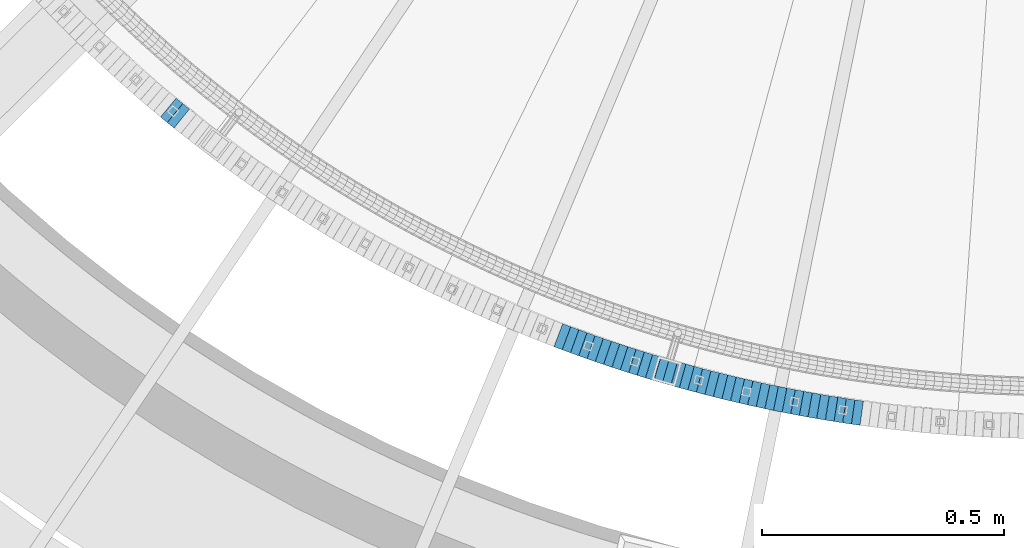
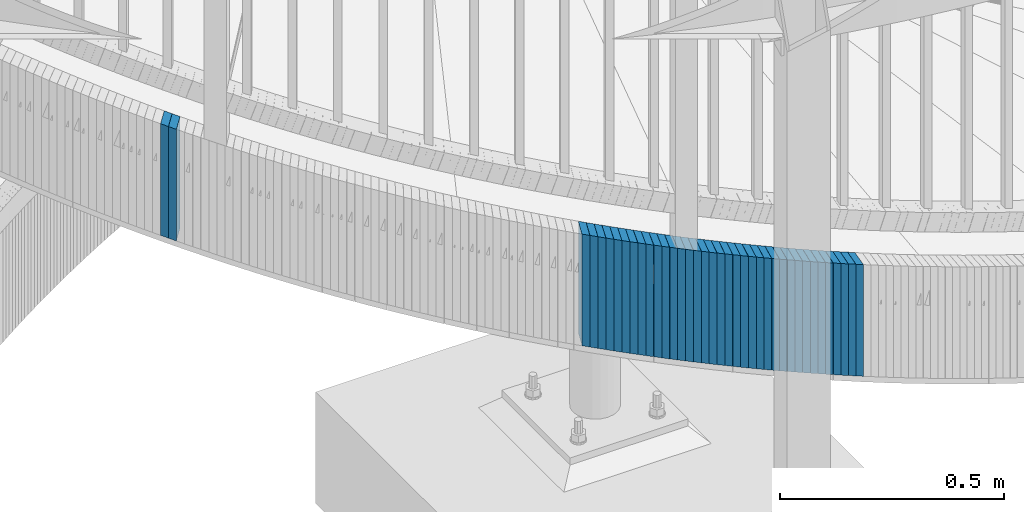
# One storey, part 876 of 975: 38 plates.
"""IFC2X3 building model written with IfcOpenShell, lengths in millimetres."""

from ifc_helpers import new_model, si_unit, frame, origin_with_axes, place, context, subcontext, project, spatial, faceted_brep, material, type_object, element, save


model = new_model("IFC2X3")

# Units and contexts
model_context = context("Model", 3, precision=1e-05, world=origin_with_axes())
body_context = subcontext(model_context, "Body", "Model", "MODEL_VIEW")
ifc_project = project(units=[si_unit("LENGTHUNIT", "METRE", prefix="MILLI"), si_unit("AREAUNIT", "SQUARE_METRE"), si_unit("VOLUMEUNIT", "CUBIC_METRE"), si_unit("MASSUNIT", "GRAM", prefix="KILO"), si_unit("TIMEUNIT", "SECOND"), si_unit("PLANEANGLEUNIT", "RADIAN"), si_unit("SOLIDANGLEUNIT", "STERADIAN"), si_unit("THERMODYNAMICTEMPERATUREUNIT", "DEGREE_CELSIUS"), si_unit("LUMINOUSINTENSITYUNIT", "LUMEN")], contexts=[model_context])

# Site, building, storey
site_placement = place(None, origin_with_axes())
site = spatial("IfcSite", under=ifc_project, at=site_placement, CompositionType="ELEMENT")
building_placement = place(site_placement, origin_with_axes())
building = spatial("IfcBuilding", under=site, at=building_placement, Name="Undefined", CompositionType="ELEMENT")
storey_placement = place(building_placement, origin_with_axes())
storey = spatial("IfcBuildingStorey", under=building, at=storey_placement, Name="Undefined", CompositionType="ELEMENT", Elevation=0.0)

# Plates
ifc_material = material(Name="STEEL/A36")
plate_type = type_object("IfcPlateType", PredefinedType="NOTDEFINED")
plate_1_placement = place(storey_placement, frame((32917.5994510154, 1181.15007153534, 3687.8875000677), z_axis=(-0.773707440821246, 0.633543049853629, 0.0), x_axis=(0.0, 0.0, 1.0)))
element("IfcPlate", 1, at=plate_1_placement, inside=storey, type_object=plate_type, material=ifc_material, Name="WALL", context=body_context, shape_type="Brep", body=[
    faceted_brep([(0.0, -25.3999999999724, -1.81898940354586e-11), (5.80000019073486, -25.3999999999614, 17.8392829894583), (5.80000019073486, 25.3999999999578, 17.8392829895529), (0.0, 25.3999999999869, 1.45519152283669e-11), (310.600006103516, -25.3999999999614, 17.8392829894583), (310.600006103516, 25.3999999999578, 17.8392829895529), (304.799987792969, -25.3999999999724, -1.81898940354586e-11), (304.799987792969, 25.3999999999869, 1.45519152283669e-11)], [[[0, 1, 2, 3]], [[1, 4, 5, 2]], [[4, 6, 7, 5]], [[6, 0, 3, 7]], [[5, 7, 3, 2]], [[6, 4, 1, 0]]]),
])
plate_2_placement = place(storey_placement, frame((32931.5690543683, 1169.79328279068, 3682.1875000677), z_axis=(-0.775943218161469, 0.630802760131266, 0.0), x_axis=(0.0, 0.0, 1.0)))
element("IfcPlate", 2, at=plate_2_placement, inside=storey, type_object=plate_type, material=ifc_material, Name="WALL", context=body_context, shape_type="Brep", body=[
    faceted_brep([(0.0, -25.3999999999724, -1.81898940354586e-11), (5.69999980926514, -25.4000000000633, 17.9075393677485), (5.69999980926514, 25.3999999999905, 17.9075393676903), (0.0, 25.3999999999869, 1.45519152283669e-11), (310.5, -25.4000000000633, 17.9075393677485), (310.5, 25.3999999999905, 17.9075393676903), (304.799987792969, -25.3999999999724, -1.81898940354586e-11), (304.799987792969, 25.3999999999869, 1.45519152283669e-11)], [[[0, 1, 2, 3]], [[1, 4, 5, 2]], [[4, 6, 7, 5]], [[6, 0, 3, 7]], [[5, 7, 3, 2]], [[6, 4, 1, 0]]]),
])
plate_3_placement = place(storey_placement, frame((33727.3261406016, 715.337070082872, 3389.5875000677), z_axis=(-0.935636632330691, 0.35296471812475, 0.0), x_axis=(0.0, 0.0, 1.0)))
element("IfcPlate", 3, at=plate_3_placement, inside=storey, type_object=plate_type, material=ifc_material, Name="WALL", context=body_context, shape_type="Brep", body=[
    faceted_brep([(0.0, -25.3999999999724, -1.81898940354586e-11), (5.80000019073486, -25.4000000000306, 17.853010177645), (5.80000019073486, 25.3999999999578, 17.8530101776596), (0.0, 25.3999999999869, 1.45519152283669e-11), (310.600006103516, -25.4000000000306, 17.853010177645), (310.600006103516, 25.3999999999578, 17.8530101776596), (304.799987792969, -25.3999999999724, -1.81898940354586e-11), (304.799987792969, 25.3999999999869, 1.45519152283669e-11)], [[[0, 1, 2, 3]], [[1, 4, 5, 2]], [[4, 6, 7, 5]], [[6, 0, 3, 7]], [[5, 7, 3, 2]], [[6, 4, 1, 0]]]),
])
plate_4_placement = place(storey_placement, frame((33744.2973835295, 709.073172312041, 3383.8875000677), z_axis=(-0.938152292731597, 0.346222869900947, 0.0), x_axis=(0.0, 0.0, 1.0)))
element("IfcPlate", 4, at=plate_4_placement, inside=storey, type_object=plate_type, material=ifc_material, Name="WALL", context=body_context, shape_type="Brep", body=[
    faceted_brep([(0.0, -25.3999999999724, -1.81898940354586e-11), (5.69999980926514, -25.4000000000633, 17.9075393677485), (5.69999980926514, 25.3999999999905, 17.9075393676903), (0.0, 25.3999999999869, 1.45519152283669e-11), (310.5, -25.4000000000633, 17.9075393677485), (310.5, 25.3999999999905, 17.9075393676903), (304.799987792969, -25.3999999999724, -1.81898940354586e-11), (304.799987792969, 25.3999999999869, 1.45519152283669e-11)], [[[0, 1, 2, 3]], [[1, 4, 5, 2]], [[4, 6, 7, 5]], [[6, 0, 3, 7]], [[5, 7, 3, 2]], [[6, 4, 1, 0]]]),
])
plate_5_placement = place(storey_placement, frame((33761.2225821276, 702.927341048499, 3378.1875000677), z_axis=(-0.939956673199756, 0.34129379207253, 0.0), x_axis=(0.0, 0.0, 1.0)))
element("IfcPlate", 5, at=plate_5_placement, inside=storey, type_object=plate_type, material=ifc_material, Name="WALL", context=body_context, shape_type="Brep", body=[
    faceted_brep([(0.0, -25.3999999999724, -1.81898940354586e-11), (5.69999980926514, -25.3999999999469, 17.8731651305425), (5.69999980926514, 25.3999999999869, 17.8731651306334), (0.0, 25.3999999999869, 1.45519152283669e-11), (310.5, -25.3999999999469, 17.8731651305425), (310.5, 25.3999999999869, 17.8731651306334), (304.799987792969, -25.3999999999724, -1.81898940354586e-11), (304.799987792969, 25.3999999999869, 1.45519152283669e-11)], [[[0, 1, 2, 3]], [[1, 4, 5, 2]], [[4, 6, 7, 5]], [[6, 0, 3, 7]], [[5, 7, 3, 2]], [[6, 4, 1, 0]]]),
])
plate_6_placement = place(storey_placement, frame((33778.1484999537, 696.881995992036, 3372.4875000677), z_axis=(-0.941741911640086, 0.33633639687146, 0.0), x_axis=(0.0, 0.0, 1.0)))
element("IfcPlate", 6, at=plate_6_placement, inside=storey, type_object=plate_type, material=ifc_material, Name="WALL", context=body_context, shape_type="Brep", body=[
    faceted_brep([(0.0, -25.3999999999724, -1.81898940354586e-11), (5.69999980926514, -25.3999999999651, 17.8440475463649), (5.69999980926514, 25.3999999999942, 17.8440475463904), (0.0, 25.3999999999869, 1.45519152283669e-11), (310.5, -25.3999999999651, 17.8440475463649), (310.5, 25.3999999999942, 17.8440475463904), (304.799987792969, -25.3999999999724, -1.81898940354586e-11), (304.799987792969, 25.3999999999869, 1.45519152283669e-11)], [[[0, 1, 2, 3]], [[1, 4, 5, 2]], [[4, 6, 7, 5]], [[6, 0, 3, 7]], [[5, 7, 3, 2]], [[6, 4, 1, 0]]]),
])
plate_7_placement = place(storey_placement, frame((33795.2195080317, 690.921609175996, 3366.6875000677), z_axis=(-0.944119345339113, 0.32960379511839, 0.0), x_axis=(0.0, 0.0, 1.0)))
element("IfcPlate", 7, at=plate_7_placement, inside=storey, type_object=plate_type, material=ifc_material, Name="WALL", context=body_context, shape_type="Brep", body=[
    faceted_brep([(0.0, -25.3999999999724, -1.81898940354586e-11), (5.80000019073486, -25.399999999936, 17.9011173247382), (5.80000019073486, 25.3999999999578, 17.9011173248837), (0.0, 25.3999999999869, 1.45519152283669e-11), (310.600006103516, -25.399999999936, 17.9011173247382), (310.600006103516, 25.3999999999578, 17.9011173248837), (304.799987792969, -25.3999999999724, -1.81898940354586e-11), (304.799987792969, 25.3999999999869, 1.45519152283669e-11)], [[[0, 1, 2, 3]], [[1, 4, 5, 2]], [[4, 6, 7, 5]], [[6, 0, 3, 7]], [[5, 7, 3, 2]], [[6, 4, 1, 0]]]),
])
plate_8_placement = place(storey_placement, frame((33812.246338152, 685.077706783121, 3360.9875000677), z_axis=(-0.945847786021473, 0.324610483007371, 0.0), x_axis=(0.0, 0.0, 1.0)))
element("IfcPlate", 8, at=plate_8_placement, inside=storey, type_object=plate_type, material=ifc_material, Name="WALL", context=body_context, shape_type="Brep", body=[
    faceted_brep([(0.0, -25.3999999999724, -1.81898940354586e-11), (5.69999980926514, -25.3999999999469, 17.8731651305425), (5.69999980926514, 25.3999999999869, 17.8731651306334), (0.0, 25.3999999999869, 1.45519152283669e-11), (310.5, -25.3999999999469, 17.8731651305425), (310.5, 25.3999999999869, 17.8731651306334), (304.799987792969, -25.3999999999724, -1.81898940354586e-11), (304.799987792969, 25.3999999999869, 1.45519152283669e-11)], [[[0, 1, 2, 3]], [[1, 4, 5, 2]], [[4, 6, 7, 5]], [[6, 0, 3, 7]], [[5, 7, 3, 2]], [[6, 4, 1, 0]]]),
])
plate_9_placement = place(storey_placement, frame((33829.2738614256, 679.334319031941, 3355.2875000677), z_axis=(-0.947555965244538, 0.319589882082478, 0.0), x_axis=(0.0, 0.0, 1.0)))
element("IfcPlate", 9, at=plate_9_placement, inside=storey, type_object=plate_type, material=ifc_material, Name="WALL", context=body_context, shape_type="Brep", body=[
    faceted_brep([(0.0, -25.3999999999724, -1.81898940354586e-11), (5.69999980926514, -25.3999999999651, 17.8440475463649), (5.69999980926514, 25.3999999999942, 17.8440475463904), (0.0, 25.3999999999869, 1.45519152283669e-11), (310.5, -25.3999999999651, 17.8440475463649), (310.5, 25.3999999999942, 17.8440475463904), (304.799987792969, -25.3999999999724, -1.81898940354586e-11), (304.799987792969, 25.3999999999869, 1.45519152283669e-11)], [[[0, 1, 2, 3]], [[1, 4, 5, 2]], [[4, 6, 7, 5]], [[6, 0, 3, 7]], [[5, 7, 3, 2]], [[6, 4, 1, 0]]]),
])
plate_10_placement = place(storey_placement, frame((33846.5728091878, 673.735549774451, 3349.4875000677), z_axis=(-0.951444518718076, 0.30782028490879, 0.0), x_axis=(0.0, 0.0, 1.0)))
element("IfcPlate", 10, at=plate_10_placement, inside=storey, type_object=plate_type, material=ifc_material, Name="WALL", context=body_context, shape_type="Brep", body=[
    faceted_brep([(0.0, -25.3999999999724, -1.81898940354586e-11), (5.80000019073486, -25.3999999999705, 17.873443603421), (5.80000019073486, 25.3999999999924, 17.8734436035338), (0.0, 25.3999999999869, 1.45519152283669e-11), (310.600006103516, -25.3999999999705, 17.873443603421), (310.600006103516, 25.3999999999924, 17.8734436035338), (304.799987792969, -25.3999999999724, -1.81898940354586e-11), (304.799987792969, 25.3999999999869, 1.45519152283669e-11)], [[[0, 1, 2, 3]], [[1, 4, 5, 2]], [[4, 6, 7, 5]], [[6, 0, 3, 7]], [[5, 7, 3, 2]], [[6, 4, 1, 0]]]),
])
plate_11_placement = place(storey_placement, frame((33863.5728091818, 668.235549775147, 3343.7875000677), z_axis=(-0.951444518718076, 0.30782028490879, 0.0), x_axis=(0.0, 0.0, 1.0)))
element("IfcPlate", 11, at=plate_11_placement, inside=storey, type_object=plate_type, material=ifc_material, Name="WALL", context=body_context, shape_type="Brep", body=[
    faceted_brep([(0.0, -25.3999999999724, -1.81898940354586e-11), (5.69999980926514, -25.3999999999469, 17.8731651305425), (5.69999980926514, 25.3999999999869, 17.8731651306334), (0.0, 25.3999999999869, 1.45519152283669e-11), (310.5, -25.3999999999469, 17.8731651305425), (310.5, 25.3999999999869, 17.8731651306334), (304.799987792969, -25.3999999999724, -1.81898940354586e-11), (304.799987792969, 25.3999999999869, 1.45519152283669e-11)], [[[0, 1, 2, 3]], [[1, 4, 5, 2]], [[4, 6, 7, 5]], [[6, 0, 3, 7]], [[5, 7, 3, 2]], [[6, 4, 1, 0]]]),
])
plate_12_placement = place(storey_placement, frame((33880.9718300514, 662.840843235734, 3338.0875000677), z_axis=(-0.95517312266217, 0.296047809895292, 0.0), x_axis=(0.0, 0.0, 1.0)))
element("IfcPlate", 12, at=plate_12_placement, inside=storey, type_object=plate_type, material=ifc_material, Name="WALL", context=body_context, shape_type="Brep", body=[
    faceted_brep([(0.0, -25.3999999999724, -1.81898940354586e-11), (5.69999980926514, -25.3999999999978, 17.9011173248218), (5.69999980926514, 25.4000000000087, 17.9011173248182), (0.0, 25.3999999999869, 1.45519152283669e-11), (310.5, -25.3999999999978, 17.9011173248218), (310.5, 25.4000000000087, 17.9011173248182), (304.799987792969, -25.3999999999724, -1.81898940354586e-11), (304.799987792969, 25.3999999999869, 1.45519152283669e-11)], [[[0, 1, 2, 3]], [[1, 4, 5, 2]], [[4, 6, 7, 5]], [[6, 0, 3, 7]], [[5, 7, 3, 2]], [[6, 4, 1, 0]]]),
])
plate_13_placement = place(storey_placement, frame((33898.0718300557, 657.540843236489, 3332.2875000677), z_axis=(-0.95517312266217, 0.296047809895292, 0.0), x_axis=(0.0, 0.0, 1.0)))
element("IfcPlate", 13, at=plate_13_placement, inside=storey, type_object=plate_type, material=ifc_material, Name="WALL", context=body_context, shape_type="Brep", body=[
    faceted_brep([(0.0, -25.3999999999724, -1.81898940354586e-11), (5.80000019073486, -25.399999999936, 17.9011173247382), (5.80000019073486, 25.3999999999578, 17.9011173248837), (0.0, 25.3999999999869, 1.45519152283669e-11), (310.600006103516, -25.399999999936, 17.9011173247382), (310.600006103516, 25.3999999999578, 17.9011173248837), (304.799987792969, -25.3999999999724, -1.81898940354586e-11), (304.799987792969, 25.3999999999869, 1.45519152283669e-11)], [[[0, 1, 2, 3]], [[1, 4, 5, 2]], [[4, 6, 7, 5]], [[6, 0, 3, 7]], [[5, 7, 3, 2]], [[6, 4, 1, 0]]]),
])
plate_14_placement = place(storey_placement, frame((33915.4319943448, 652.361731430617, 3326.5875000677), z_axis=(-0.958287760646571, 0.285805122058686, -5.19926288689022e-11), x_axis=(0.0, 0.0, 1.0)))
element("IfcPlate", 14, at=plate_14_placement, inside=storey, type_object=plate_type, material=ifc_material, Name="WALL", context=body_context, shape_type="Brep", body=[
    faceted_brep([(0.0, -25.3999999999724, -1.81898940354586e-11), (5.69999980926514, -25.3999999999651, 17.8440475463649), (5.69999980926514, 25.3999999999942, 17.8440475463904), (0.0, 25.3999999999869, 1.45519152283669e-11), (310.5, -25.3999999999651, 17.8440475463649), (310.5, 25.3999999999942, 17.8440475463904), (304.799987792969, -25.3999999999724, -1.81898940354586e-11), (304.799987792969, 25.3999999999869, 1.45519152283669e-11)], [[[0, 1, 2, 3]], [[1, 4, 5, 2]], [[4, 6, 7, 5]], [[6, 0, 3, 7]], [[5, 7, 3, 2]], [[6, 4, 1, 0]]]),
])
plate_15_placement = place(storey_placement, frame((33932.8012284135, 647.311897447003, 3320.7875000677), z_axis=(-0.96024972858431, 0.279142362879158, 0.0), x_axis=(0.0, 0.0, 1.0)))
element("IfcPlate", 15, at=plate_15_placement, inside=storey, type_object=plate_type, material=ifc_material, Name="WALL", context=body_context, shape_type="Brep", body=[
    faceted_brep([(0.0, -25.3999999999724, -1.81898940354586e-11), (5.80000019073486, -25.3999999999905, 17.9067020416114), (5.80000019073486, 25.399999999976, 17.9067020416369), (0.0, 25.3999999999869, 1.45519152283669e-11), (310.600006103516, -25.3999999999905, 17.9067020416114), (310.600006103516, 25.399999999976, 17.9067020416369), (304.799987792969, -25.3999999999724, -1.81898940354586e-11), (304.799987792969, 25.3999999999869, 1.45519152283669e-11)], [[[0, 1, 2, 3]], [[1, 4, 5, 2]], [[4, 6, 7, 5]], [[6, 0, 3, 7]], [[5, 7, 3, 2]], [[6, 4, 1, 0]]]),
])
plate_16_placement = place(storey_placement, frame((33950.0012284237, 642.311897446904, 3315.0875000677), z_axis=(-0.96024972858431, 0.279142362879158, 0.0), x_axis=(0.0, 0.0, 1.0)))
element("IfcPlate", 16, at=plate_16_placement, inside=storey, type_object=plate_type, material=ifc_material, Name="WALL", context=body_context, shape_type="Brep", body=[
    faceted_brep([(0.0, -25.3999999999724, -1.81898940354586e-11), (5.69999980926514, -25.4000000000633, 17.9075393677485), (5.69999980926514, 25.3999999999905, 17.9075393676903), (0.0, 25.3999999999869, 1.45519152283669e-11), (310.5, -25.4000000000633, 17.9075393677485), (310.5, 25.3999999999905, 17.9075393676903), (304.799987792969, -25.3999999999724, -1.81898940354586e-11), (304.799987792969, 25.3999999999869, 1.45519152283669e-11)], [[[0, 1, 2, 3]], [[1, 4, 5, 2]], [[4, 6, 7, 5]], [[6, 0, 3, 7]], [[5, 7, 3, 2]], [[6, 4, 1, 0]]]),
])
plate_17_placement = place(storey_placement, frame((33967.6005873547, 637.426859859257, 3309.3875000677), z_axis=(-0.963597665099577, 0.267356578027627, 0.0), x_axis=(0.0, 0.0, 1.0)))
element("IfcPlate", 17, at=plate_17_placement, inside=storey, type_object=plate_type, material=ifc_material, Name="WALL", context=body_context, shape_type="Brep", body=[
    faceted_brep([(0.0, -25.3999999999724, -1.81898940354586e-11), (5.69999980926514, -25.4000000000342, 17.9493732452938), (5.69999980926514, 25.4000000000415, 17.9493732451738), (0.0, 25.3999999999869, 1.45519152283669e-11), (310.5, -25.4000000000342, 17.9493732452938), (310.5, 25.4000000000415, 17.9493732451738), (304.799987792969, -25.3999999999724, -1.81898940354586e-11), (304.799987792969, 25.3999999999869, 1.45519152283669e-11)], [[[0, 1, 2, 3]], [[1, 4, 5, 2]], [[4, 6, 7, 5]], [[6, 0, 3, 7]], [[5, 7, 3, 2]], [[6, 4, 1, 0]]]),
])
for number, where, z_axis, x_axis, name in (
    (18, (33985.0322430294, 632.69071190803, 3303.5875000677), (-0.965020812823148, 0.262173283951953, 0.0), (0.0, 0.0, 1.0), "WALL"),
    (19, (34002.3322430346, 627.990711908945, 3297.7875000677), (-0.965020812823148, 0.262173283951953, 0.0), (0.0, 0.0, 1.0), "WALL"),
):
    element("IfcPlate", number, at=place(storey_placement, frame(where, z_axis=z_axis, x_axis=x_axis)), inside=storey, type_object=plate_type, material=ifc_material, Name=name, context=body_context, shape_type="Brep", body=[
        faceted_brep([(0.0, -25.3999999999724, -1.81898940354586e-11), (5.80000019073486, -25.3999999999833, 17.9287471770986), (5.80000019073486, 25.4000000000087, 17.9287471771167), (0.0, 25.3999999999869, 1.45519152283669e-11), (310.600006103516, -25.3999999999833, 17.9287471770986), (310.600006103516, 25.4000000000087, 17.9287471771167), (304.799987792969, -25.3999999999724, -1.81898940354586e-11), (304.799987792969, 25.3999999999869, 1.45519152283669e-11)], [[[0, 1, 2, 3]], [[1, 4, 5, 2]], [[4, 6, 7, 5]], [[6, 0, 3, 7]], [[5, 7, 3, 2]], [[6, 4, 1, 0]]]),
    ])
plate_18_placement = place(storey_placement, frame((34020.0317207628, 623.41130900027, 3292.0875000677), z_axis=(-0.968146911628319, 0.250382821903876, 0.0), x_axis=(0.0, 0.0, 1.0)))
element("IfcPlate", 20, at=plate_18_placement, inside=storey, type_object=plate_type, material=ifc_material, Name="WALL", context=body_context, shape_type="Brep", body=[
    faceted_brep([(0.0, -25.3999999999724, -1.81898940354586e-11), (5.69999980926514, -25.3999999999978, 17.9738693237196), (5.69999980926514, 25.4000000000178, 17.9738693236577), (0.0, 25.3999999999869, 1.45519152283669e-11), (310.5, -25.3999999999978, 17.9738693237196), (310.5, 25.4000000000178, 17.9738693236577), (304.799987792969, -25.3999999999724, -1.81898940354586e-11), (304.799987792969, 25.3999999999869, 1.45519152283669e-11)], [[[0, 1, 2, 3]], [[1, 4, 5, 2]], [[4, 6, 7, 5]], [[6, 0, 3, 7]], [[5, 7, 3, 2]], [[6, 4, 1, 0]]]),
])
plate_19_placement = place(storey_placement, frame((34037.4306501892, 618.985935893361, 3286.3875000677), z_axis=(-0.969145852858996, 0.246487962964138, 0.0), x_axis=(0.0, 0.0, 1.0)))
element("IfcPlate", 21, at=plate_19_placement, inside=storey, type_object=plate_type, material=ifc_material, Name="WALL", context=body_context, shape_type="Brep", body=[
    faceted_brep([(0.0, -25.3999999999724, -1.81898940354586e-11), (5.69999980926514, -25.4000000000196, 17.8538513183848), (5.69999980926514, 25.4000000000415, 17.8538513183157), (0.0, 25.3999999999869, 1.45519152283669e-11), (310.5, -25.4000000000196, 17.8538513183848), (310.5, 25.4000000000415, 17.8538513183157), (304.799987792969, -25.3999999999724, -1.81898940354586e-11), (304.799987792969, 25.3999999999869, 1.45519152283669e-11)], [[[0, 1, 2, 3]], [[1, 4, 5, 2]], [[4, 6, 7, 5]], [[6, 0, 3, 7]], [[5, 7, 3, 2]], [[6, 4, 1, 0]]]),
])
plate_20_placement = place(storey_placement, frame((34054.9977509856, 614.644039084407, 3280.5875000677), z_axis=(-0.970795333552335, 0.23990919188937, 0.0), x_axis=(0.0, 0.0, 1.0)))
element("IfcPlate", 22, at=plate_20_placement, inside=storey, type_object=plate_type, material=ifc_material, Name="WALL", context=body_context, shape_type="Brep", body=[
    faceted_brep([(0.0, -25.3999999999724, -1.81898940354586e-11), (5.80000019073486, -25.4000000000233, 17.9178676605334), (5.80000019073486, 25.3999999999942, 17.9178676605297), (0.0, 25.3999999999869, 1.45519152283669e-11), (310.600006103516, -25.4000000000233, 17.9178676605334), (310.600006103516, 25.3999999999942, 17.9178676605297), (304.799987792969, -25.3999999999724, -1.81898940354586e-11), (304.799987792969, 25.3999999999869, 1.45519152283669e-11)], [[[0, 1, 2, 3]], [[1, 4, 5, 2]], [[4, 6, 7, 5]], [[6, 0, 3, 7]], [[5, 7, 3, 2]], [[6, 4, 1, 0]]]),
])
plate_21_placement = place(storey_placement, frame((34072.3977509968, 610.344039084932, 3274.8875000677), z_axis=(-0.970795333552335, 0.23990919188937, 0.0), x_axis=(0.0, 0.0, 1.0)))
element("IfcPlate", 23, at=plate_21_placement, inside=storey, type_object=plate_type, material=ifc_material, Name="WALL", context=body_context, shape_type="Brep", body=[
    faceted_brep([(0.0, -25.3999999999724, -1.81898940354586e-11), (5.69999980926514, -25.3999999999724, 17.9212169646999), (5.69999980926514, 25.3999999999651, 17.9212169647544), (0.0, 25.3999999999869, 1.45519152283669e-11), (310.5, -25.3999999999724, 17.9212169646999), (310.5, 25.3999999999651, 17.9212169647544), (304.799987792969, -25.3999999999724, -1.81898940354586e-11), (304.799987792969, 25.3999999999869, 1.45519152283669e-11)], [[[0, 1, 2, 3]], [[1, 4, 5, 2]], [[4, 6, 7, 5]], [[6, 0, 3, 7]], [[5, 7, 3, 2]], [[6, 4, 1, 0]]]),
])
plate_22_placement = place(storey_placement, frame((34090.2007954729, 606.247917420197, 3269.0875000677), z_axis=(-0.974579651097025, 0.224041299022304, 0.0), x_axis=(0.0, 0.0, 1.0)))
element("IfcPlate", 24, at=plate_22_placement, inside=storey, type_object=plate_type, material=ifc_material, Name="WALL", context=body_context, shape_type="Brep", body=[
    faceted_brep([(0.0, -25.3999999999724, -1.81898940354586e-11), (5.80000019073486, -25.4000000000306, 17.853010177645), (5.80000019073486, 25.3999999999578, 17.8530101776596), (0.0, 25.3999999999869, 1.45519152283669e-11), (310.600006103516, -25.4000000000306, 17.853010177645), (310.600006103516, 25.3999999999578, 17.8530101776596), (304.799987792969, -25.3999999999724, -1.81898940354586e-11), (304.799987792969, 25.3999999999869, 1.45519152283669e-11)], [[[0, 1, 2, 3]], [[1, 4, 5, 2]], [[4, 6, 7, 5]], [[6, 0, 3, 7]], [[5, 7, 3, 2]], [[6, 4, 1, 0]]]),
])
plate_23_placement = place(storey_placement, frame((34107.6007954703, 602.247917420198, 3263.3875000677), z_axis=(-0.974579651097025, 0.224041299022304, 0.0), x_axis=(0.0, 0.0, 1.0)))
element("IfcPlate", 25, at=plate_23_placement, inside=storey, type_object=plate_type, material=ifc_material, Name="WALL", context=body_context, shape_type="Brep", body=[
    faceted_brep([(0.0, -25.3999999999724, -1.81898940354586e-11), (5.69999980926514, -25.4000000000196, 17.8538513183848), (5.69999980926514, 25.4000000000415, 17.8538513183157), (0.0, 25.3999999999869, 1.45519152283669e-11), (310.5, -25.4000000000196, 17.8538513183848), (310.5, 25.4000000000415, 17.8538513183157), (304.799987792969, -25.3999999999724, -1.81898940354586e-11), (304.799987792969, 25.3999999999869, 1.45519152283669e-11)], [[[0, 1, 2, 3]], [[1, 4, 5, 2]], [[4, 6, 7, 5]], [[6, 0, 3, 7]], [[5, 7, 3, 2]], [[6, 4, 1, 0]]]),
])
plate_24_placement = place(storey_placement, frame((34125.2664117393, 598.310427121475, 3257.6875000677), z_axis=(-0.976055647129105, 0.217520973028772, 0.0), x_axis=(0.0, 0.0, 1.0)))
element("IfcPlate", 26, at=plate_24_placement, inside=storey, type_object=plate_type, material=ifc_material, Name="WALL", context=body_context, shape_type="Brep", body=[
    faceted_brep([(0.0, -25.3999999999724, -1.81898940354586e-11), (5.69999980926514, -25.3999999999896, 17.9334888457815), (5.69999980926514, 25.3999999999869, 17.9334888458907), (0.0, 25.3999999999869, 1.45519152283669e-11), (310.5, -25.3999999999896, 17.9334888457815), (310.5, 25.3999999999869, 17.9334888458907), (304.799987792969, -25.3999999999724, -1.81898940354586e-11), (304.799987792969, 25.3999999999869, 1.45519152283669e-11)], [[[0, 1, 2, 3]], [[1, 4, 5, 2]], [[4, 6, 7, 5]], [[6, 0, 3, 7]], [[5, 7, 3, 2]], [[6, 4, 1, 0]]]),
])
plate_25_placement = place(storey_placement, frame((34142.9016202032, 594.480681491046, 3251.8875000677), z_axis=(-0.97722673497773, 0.212197804995164, 0.0), x_axis=(0.0, 0.0, 1.0)))
element("IfcPlate", 27, at=plate_25_placement, inside=storey, type_object=plate_type, material=ifc_material, Name="WALL", context=body_context, shape_type="Brep", body=[
    faceted_brep([(0.0, -25.3999999999724, -1.81898940354586e-11), (5.80000019073486, -25.3999999999905, 17.9067020416114), (5.80000019073486, 25.399999999976, 17.9067020416369), (0.0, 25.3999999999869, 1.45519152283669e-11), (310.600006103516, -25.3999999999905, 17.9067020416114), (310.600006103516, 25.399999999976, 17.9067020416369), (304.799987792969, -25.3999999999724, -1.81898940354586e-11), (304.799987792969, 25.3999999999869, 1.45519152283669e-11)], [[[0, 1, 2, 3]], [[1, 4, 5, 2]], [[4, 6, 7, 5]], [[6, 0, 3, 7]], [[5, 7, 3, 2]], [[6, 4, 1, 0]]]),
])
plate_26_placement = place(storey_placement, frame((34160.673471648, 590.823206123946, 3246.1875000677), z_axis=(-0.979489544723104, 0.20149499194304, 0.0), x_axis=(0.0, 0.0, 1.0)))
element("IfcPlate", 28, at=plate_26_placement, inside=storey, type_object=plate_type, material=ifc_material, Name="WALL", context=body_context, shape_type="Brep", body=[
    faceted_brep([(0.0, -25.3999999999724, -1.81898940354586e-11), (5.69999980926514, -25.3999999999469, 17.8731651305425), (5.69999980926514, 25.3999999999869, 17.8731651306334), (0.0, 25.3999999999869, 1.45519152283669e-11), (310.5, -25.3999999999469, 17.8731651305425), (310.5, 25.3999999999869, 17.8731651306334), (304.799987792969, -25.3999999999724, -1.81898940354586e-11), (304.799987792969, 25.3999999999869, 1.45519152283669e-11)], [[[0, 1, 2, 3]], [[1, 4, 5, 2]], [[4, 6, 7, 5]], [[6, 0, 3, 7]], [[5, 7, 3, 2]], [[6, 4, 1, 0]]]),
])
plate_27_placement = place(storey_placement, frame((34178.3100946324, 587.295491396807, 3240.4875000677), z_axis=(-0.980580675729382, 0.196116134945876, 0.0), x_axis=(0.0, 0.0, 1.0)))
element("IfcPlate", 29, at=plate_27_placement, inside=storey, type_object=plate_type, material=ifc_material, Name="WALL", context=body_context, shape_type="Brep", body=[
    faceted_brep([(0.0, -25.3999999999724, -1.81898940354586e-11), (5.69999980926514, -25.4000000000196, 17.8538513183848), (5.69999980926514, 25.4000000000415, 17.8538513183157), (0.0, 25.3999999999869, 1.45519152283669e-11), (310.5, -25.4000000000196, 17.8538513183848), (310.5, 25.4000000000415, 17.8538513183157), (304.799987792969, -25.3999999999724, -1.81898940354586e-11), (304.799987792969, 25.3999999999869, 1.45519152283669e-11)], [[[0, 1, 2, 3]], [[1, 4, 5, 2]], [[4, 6, 7, 5]], [[6, 0, 3, 7]], [[5, 7, 3, 2]], [[6, 4, 1, 0]]]),
])
plate_28_placement = place(storey_placement, frame((34195.9471687361, 583.868468430123, 3234.6875000677), z_axis=(-0.98164457204821, 0.190719517009368, 0.0), x_axis=(0.0, 0.0, 1.0)))
element("IfcPlate", 30, at=plate_28_placement, inside=storey, type_object=plate_type, material=ifc_material, Name="WALL", context=body_context, shape_type="Brep", body=[
    faceted_brep([(0.0, -25.3999999999724, -1.81898940354586e-11), (5.80000019073486, -25.3999999999796, 17.8280677795228), (5.80000019073486, 25.4000000000196, 17.8280677795265), (0.0, 25.3999999999869, 1.45519152283669e-11), (310.600006103516, -25.3999999999796, 17.8280677795228), (310.600006103516, 25.4000000000196, 17.8280677795265), (304.799987792969, -25.3999999999724, -1.81898940354586e-11), (304.799987792969, 25.3999999999869, 1.45519152283669e-11)], [[[0, 1, 2, 3]], [[1, 4, 5, 2]], [[4, 6, 7, 5]], [[6, 0, 3, 7]], [[5, 7, 3, 2]], [[6, 4, 1, 0]]]),
])
plate_29_placement = place(storey_placement, frame((34213.7105156745, 580.5372870119, 3228.9875000677), z_axis=(-0.982872186945643, 0.184288534989808, 0.0), x_axis=(0.0, 0.0, 1.0)))
element("IfcPlate", 31, at=plate_29_placement, inside=storey, type_object=plate_type, material=ifc_material, Name="WALL", context=body_context, shape_type="Brep", body=[
    faceted_brep([(0.0, -25.3999999999724, -1.81898940354586e-11), (5.69999980926514, -25.4000000000633, 17.9075393677485), (5.69999980926514, 25.3999999999905, 17.9075393676903), (0.0, 25.3999999999869, 1.45519152283669e-11), (310.5, -25.4000000000633, 17.9075393677485), (310.5, 25.3999999999905, 17.9075393676903), (304.799987792969, -25.3999999999724, -1.81898940354586e-11), (304.799987792969, 25.3999999999869, 1.45519152283669e-11)], [[[0, 1, 2, 3]], [[1, 4, 5, 2]], [[4, 6, 7, 5]], [[6, 0, 3, 7]], [[5, 7, 3, 2]], [[6, 4, 1, 0]]]),
])
plate_30_placement = place(storey_placement, frame((34231.3226281561, 577.316526292472, 3223.2875000677), z_axis=(-0.983689538117418, 0.179874658021471, 0.0), x_axis=(0.0, 0.0, 1.0)))
element("IfcPlate", 32, at=plate_30_placement, inside=storey, type_object=plate_type, material=ifc_material, Name="WALL", context=body_context, shape_type="Brep", body=[
    faceted_brep([(0.0, -25.3999999999724, -1.81898940354586e-11), (5.69999980926514, -25.4000000000251, 17.7924137116061), (5.69999980926514, 25.4000000000051, 17.7924137115479), (0.0, 25.3999999999869, 1.45519152283669e-11), (310.5, -25.4000000000251, 17.7924137116061), (310.5, 25.4000000000051, 17.7924137115479), (304.799987792969, -25.3999999999724, -1.81898940354586e-11), (304.799987792969, 25.3999999999869, 1.45519152283669e-11)], [[[0, 1, 2, 3]], [[1, 4, 5, 2]], [[4, 6, 7, 5]], [[6, 0, 3, 7]], [[5, 7, 3, 2]], [[6, 4, 1, 0]]]),
])
plate_31_placement = place(storey_placement, frame((34249.0854053129, 574.187308638839, 3217.5875000677), z_axis=(-0.984839839440118, 0.173466108077521, 0.0), x_axis=(0.0, 0.0, 1.0)))
element("IfcPlate", 33, at=plate_31_placement, inside=storey, type_object=plate_type, material=ifc_material, Name="WALL", context=body_context, shape_type="Brep", body=[
    faceted_brep([(0.0, -25.3999999999724, -1.81898940354586e-11), (5.69999980926514, -25.3999999999469, 17.8731651305425), (5.69999980926514, 25.3999999999869, 17.8731651306334), (0.0, 25.3999999999869, 1.45519152283669e-11), (310.5, -25.3999999999469, 17.8731651305425), (310.5, 25.3999999999869, 17.8731651306334), (304.799987792969, -25.3999999999724, -1.81898940354586e-11), (304.799987792969, 25.3999999999869, 1.45519152283669e-11)], [[[0, 1, 2, 3]], [[1, 4, 5, 2]], [[4, 6, 7, 5]], [[6, 0, 3, 7]], [[5, 7, 3, 2]], [[6, 4, 1, 0]]]),
])
plate_32_placement = place(storey_placement, frame((34266.8234577207, 571.163384972053, 3211.7875000677), z_axis=(-0.985781716087097, 0.168030974014846, 0.0), x_axis=(0.0, 0.0, 1.0)))
element("IfcPlate", 34, at=plate_32_placement, inside=storey, type_object=plate_type, material=ifc_material, Name="WALL", context=body_context, shape_type="Brep", body=[
    faceted_brep([(0.0, -25.3999999999724, -1.81898940354586e-11), (5.80000019073486, -25.4000000000306, 17.853010177645), (5.80000019073486, 25.3999999999578, 17.8530101776596), (0.0, 25.3999999999869, 1.45519152283669e-11), (310.600006103516, -25.4000000000306, 17.853010177645), (310.600006103516, 25.3999999999578, 17.8530101776596), (304.799987792969, -25.3999999999724, -1.81898940354586e-11), (304.799987792969, 25.3999999999869, 1.45519152283669e-11)], [[[0, 1, 2, 3]], [[1, 4, 5, 2]], [[4, 6, 7, 5]], [[6, 0, 3, 7]], [[5, 7, 3, 2]], [[6, 4, 1, 0]]]),
])
plate_33_placement = place(storey_placement, frame((34284.8227167027, 568.314211542343, 3206.0875000677), z_axis=(-0.987717677908893, 0.156249123985588, 0.0), x_axis=(0.0, 0.0, 1.0)))
element("IfcPlate", 35, at=plate_33_placement, inside=storey, type_object=plate_type, material=ifc_material, Name="WALL", context=body_context, shape_type="Brep", body=[
    faceted_brep([(0.0, -25.3999999999724, -1.81898940354586e-11), (5.69999980926514, -25.3999999999724, 17.9212169646999), (5.69999980926514, 25.3999999999651, 17.9212169647544), (0.0, 25.3999999999869, 1.45519152283669e-11), (310.5, -25.3999999999724, 17.9212169646999), (310.5, 25.3999999999651, 17.9212169647544), (304.799987792969, -25.3999999999724, -1.81898940354586e-11), (304.799987792969, 25.3999999999869, 1.45519152283669e-11)], [[[0, 1, 2, 3]], [[1, 4, 5, 2]], [[4, 6, 7, 5]], [[6, 0, 3, 7]], [[5, 7, 3, 2]], [[6, 4, 1, 0]]]),
])
plate_34_placement = place(storey_placement, frame((34302.4007221987, 565.517700782547, 3200.3875000677), z_axis=(-0.987580306285744, 0.157115049045459, 0.0), x_axis=(0.0, 0.0, 1.0)))
element("IfcPlate", 36, at=plate_34_placement, inside=storey, type_object=plate_type, material=ifc_material, Name="WALL", context=body_context, shape_type="Brep", body=[
    faceted_brep([(0.0, -25.3999999999724, -1.81898940354586e-11), (5.69999980926514, -25.3999999999432, 17.8213348388126), (5.69999980926514, 25.3999999999905, 17.8213348388708), (0.0, 25.3999999999869, 1.45519152283669e-11), (310.5, -25.3999999999432, 17.8213348388126), (310.5, 25.3999999999905, 17.8213348388708), (304.799987792969, -25.3999999999724, -1.81898940354586e-11), (304.799987792969, 25.3999999999869, 1.45519152283669e-11)], [[[0, 1, 2, 3]], [[1, 4, 5, 2]], [[4, 6, 7, 5]], [[6, 0, 3, 7]], [[5, 7, 3, 2]], [[6, 4, 1, 0]]]),
])
plate_35_placement = place(storey_placement, frame((34320.3999845954, 562.87191775893, 3194.6875000677), z_axis=(-0.989382787518691, 0.145333064929299, 0.0), x_axis=(0.0, 0.0, 1.0)))
element("IfcPlate", 37, at=plate_35_placement, inside=storey, type_object=plate_type, material=ifc_material, Name="WALL", context=body_context, shape_type="Brep", body=[
    faceted_brep([(0.0, -25.3999999999724, -1.81898940354586e-11), (5.69999980926514, -25.3999999999614, 17.8921775817616), (5.69999980926514, 25.400000000016, 17.8921775817726), (0.0, 25.3999999999869, 1.45519152283669e-11), (310.5, -25.3999999999614, 17.8921775817616), (310.5, 25.400000000016, 17.8921775817726), (304.799987792969, -25.3999999999724, -1.81898940354586e-11), (304.799987792969, 25.3999999999869, 1.45519152283669e-11)], [[[0, 1, 2, 3]], [[1, 4, 5, 2]], [[4, 6, 7, 5]], [[6, 0, 3, 7]], [[5, 7, 3, 2]], [[6, 4, 1, 0]]]),
])
plate_36_placement = place(storey_placement, frame((34338.1193468969, 560.354673700949, 3188.8875000677), z_axis=(-0.990061687455647, 0.140633762064723, 0.0), x_axis=(0.0, 0.0, 1.0)))
element("IfcPlate", 38, at=plate_36_placement, inside=storey, type_object=plate_type, material=ifc_material, Name="WALL", context=body_context, shape_type="Brep", body=[
    faceted_brep([(0.0, -25.3999999999724, -1.81898940354586e-11), (5.80000019073486, -25.4000000000078, 17.7766704559835), (5.80000019073486, 25.3999999999915, 17.7766704559835), (0.0, 25.3999999999869, 1.45519152283669e-11), (310.600006103516, -25.4000000000078, 17.7766704559835), (310.600006103516, 25.3999999999915, 17.7766704559835), (304.799987792969, -25.3999999999724, -1.81898940354586e-11), (304.799987792969, 25.3999999999869, 1.45519152283669e-11)], [[[0, 1, 2, 3]], [[1, 4, 5, 2]], [[4, 6, 7, 5]], [[6, 0, 3, 7]], [[5, 7, 3, 2]], [[6, 4, 1, 0]]]),
])

save(model, "model.ifc")
